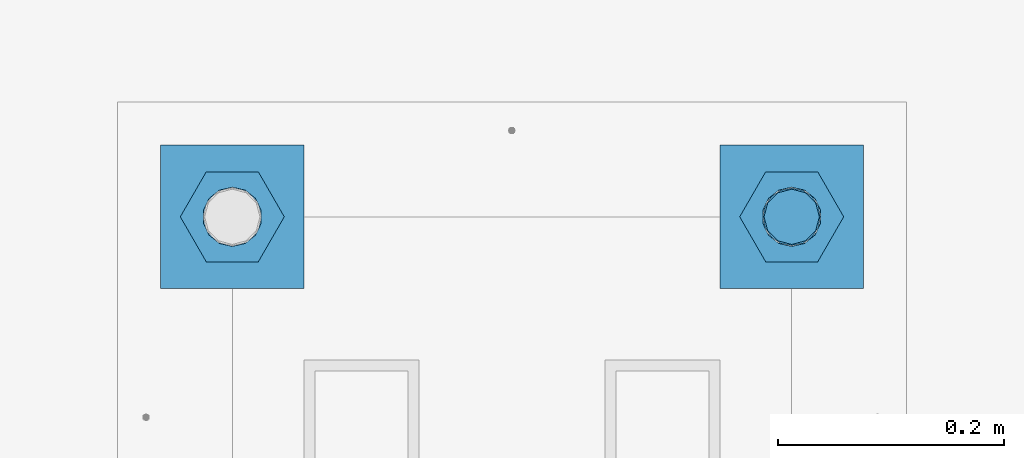
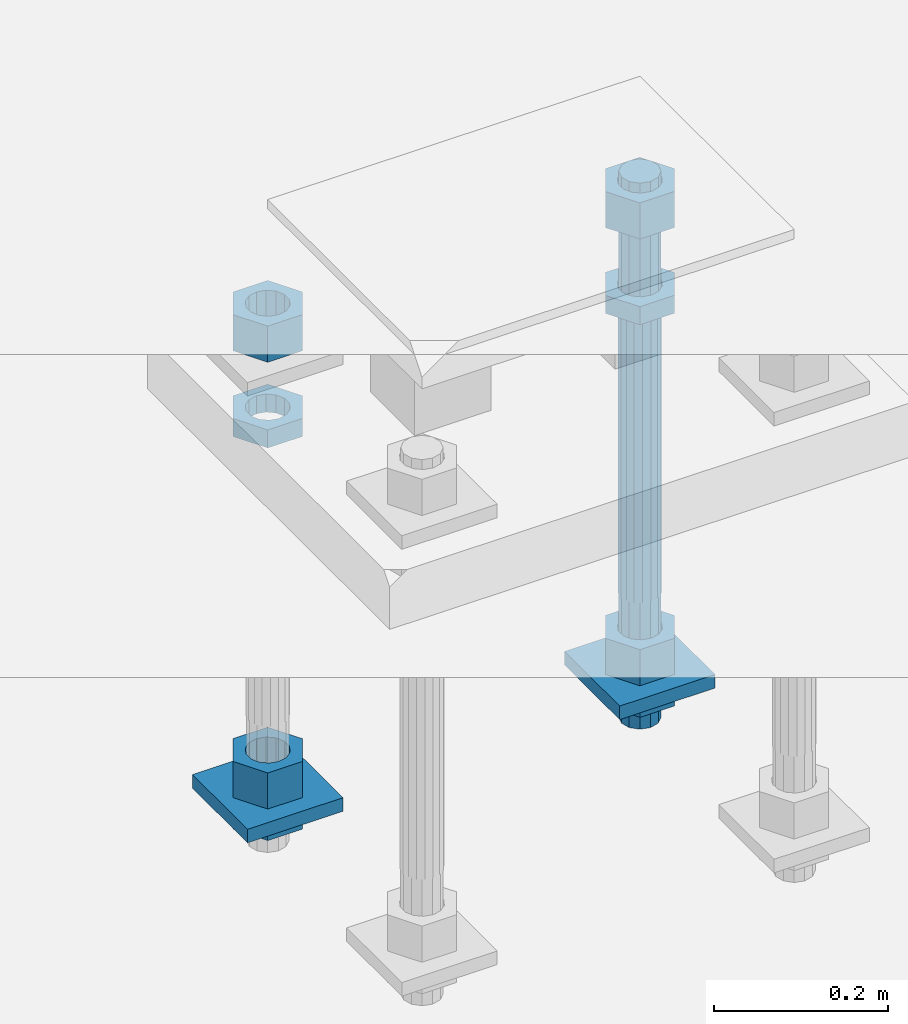
# One storey, part 2556 of 3843: 11 beams, 1 element without a shape of its own.
"""IFC2X3 building model written with IfcOpenShell, lengths in millimetres."""

from ifc_helpers import new_model, si_unit, frame, origin_with_axes, place, context, subcontext, project, spatial, faceted_brep, material, type_object, element, aggregate, save


model = new_model("IFC2X3")

# Units and contexts
model_context = context("Model", 3, precision=1e-05, world=origin_with_axes())
body_context = subcontext(model_context, "Body", "Model", "MODEL_VIEW")
ifc_project = project(units=[si_unit("LENGTHUNIT", "METRE", prefix="MILLI"), si_unit("AREAUNIT", "SQUARE_METRE"), si_unit("VOLUMEUNIT", "CUBIC_METRE"), si_unit("MASSUNIT", "GRAM", prefix="KILO"), si_unit("TIMEUNIT", "SECOND"), si_unit("PLANEANGLEUNIT", "RADIAN"), si_unit("SOLIDANGLEUNIT", "STERADIAN"), si_unit("THERMODYNAMICTEMPERATUREUNIT", "DEGREE_CELSIUS"), si_unit("LUMINOUSINTENSITYUNIT", "LUMEN")], contexts=[model_context])

# Site, building, storey
site_placement = place(None, origin_with_axes())
site = spatial("IfcSite", under=ifc_project, at=site_placement, CompositionType="ELEMENT")
building_placement = place(site_placement, origin_with_axes())
building = spatial("IfcBuilding", under=site, at=building_placement, Name="Undefined", CompositionType="ELEMENT")
storey_placement = place(building_placement, origin_with_axes())
storey = spatial("IfcBuildingStorey", under=building, at=storey_placement, Name="Undefined", CompositionType="ELEMENT", Elevation=0.0)

# Assembly, beams
assembly_placement = place(storey_placement, origin_with_axes())
assembly = element("IfcElementAssembly", 1, at=assembly_placement, inside=storey, Name="TEMPLATE", AssemblyPlace="NOTDEFINED", PredefinedType="RIGID_FRAME")
ifc_material_1 = material(Name="STEEL/A572-50")
beam_type_1 = type_object("IfcBeamType", PredefinedType="NOTDEFINED")
beam_1_placement = place(assembly_placement, frame((105403.65, 241.299998474126, 29244.925), z_axis=(-1.0, 0.0, 0.0), x_axis=(0.0, -1.0, 0.0)))
beam_1 = element("IfcBeam", 2, at=beam_1_placement, type_object=beam_type_1, material=ifc_material_1, Name="WASHER_PLATE", context=body_context, shape_type="Brep", body=[
    faceted_brep([(0.0, 9.52500000000146, -63.5), (0.0, 9.52500000000146, 63.5), (127.0, 9.52500000000146, 63.5), (127.0, 9.52500000000146, -63.5), (0.0, -9.52500000000146, 63.5), (127.0, -9.52500000000146, 63.5), (0.0, -9.52500000000146, -63.5), (127.0, -9.52500000000146, -63.5)], [[[0, 1, 2, 3]], [[1, 4, 5, 2]], [[4, 6, 7, 5]], [[6, 0, 3, 7]], [[5, 7, 3, 2]], [[6, 4, 1, 0]]]),
])
beam_2_placement = place(assembly_placement, frame((104908.35, 241.299998474126, 29244.925), z_axis=(-1.0, 0.0, 0.0), x_axis=(0.0, -1.0, 0.0)))
beam_2 = element("IfcBeam", 3, at=beam_2_placement, type_object=beam_type_1, material=ifc_material_1, Name="WASHER_PLATE", context=body_context, shape_type="Brep", body=[
    faceted_brep([(0.0, 9.52500000000146, -63.5), (0.0, 9.52500000000146, 63.5), (127.0, 9.52500000000146, 63.5), (127.0, 9.52500000000146, -63.5), (0.0, -9.52500000000146, 63.5), (127.0, -9.52500000000146, 63.5), (0.0, -9.52500000000146, -63.5), (127.0, -9.52500000000146, -63.5)], [[[0, 1, 2, 3]], [[1, 4, 5, 2]], [[4, 6, 7, 5]], [[6, 0, 3, 7]], [[5, 7, 3, 2]], [[6, 4, 1, 0]]]),
])
ifc_material_2 = material(Name="STEEL/A36")
beam_type_2 = type_object("IfcBeamType", Name="2_HALF_NUT", PredefinedType="NOTDEFINED")
beam_3_placement = place(assembly_placement, frame((105403.65, 177.799998474126, 29787.85), z_axis=(0.0, -1.0, 0.0), x_axis=(0.0, 0.0, -1.0)))
beam_3 = element("IfcBeam", 4, at=beam_3_placement, type_object=beam_type_2, material=ifc_material_2, Name="NUT", ObjectType="2_HALF_NUT", context=body_context, shape_type="Brep", body=[
    faceted_brep([(0.0, -46.0369987487793, 0.0), (0.0, -23.0184993743896, -39.869213104248), (25.4000000000015, -23.0184993743896, -39.869213104248), (25.4000000000015, -46.0369987487793, 0.0), (0.0, 23.0184993743896, -39.869213104248), (25.4000000000015, 23.0184993743896, -39.869213104248), (0.0, 46.0369987487793, 0.0), (25.4000000000015, 46.0369987487793, 0.0), (0.0, 23.0184993743896, 39.869213104248), (25.4000000000015, 23.0184993743896, 39.869213104248), (0.0, -23.0184993743896, 39.869213104248), (25.4000000000015, -23.0184993743896, 39.869213104248), (0.0, 0.0, 26.1940002441406), (0.0, 11.3650617044477, 23.5999013092805), (25.4000000000015, 11.3650617044477, 23.5999013092805), (25.4000000000015, 0.0, 26.1940002441406), (0.0, 20.4791109456419, 16.3316083006721), (25.4000000000015, 20.4791109456419, 16.3316083006721), (0.0, 25.5370200498292, 5.82867859874386), (25.4000000000015, 25.5370200498292, 5.82867859874386), (0.0, 25.5370200498292, -5.82867859874386), (25.4000000000015, 25.5370200498292, -5.82867859874386), (0.0, 20.4791109456419, -16.3316083006721), (25.4000000000015, 20.4791109456419, -16.3316083006721), (0.0, 11.3650617044477, -23.5999013092805), (25.4000000000015, 11.3650617044477, -23.5999013092805), (0.0, 0.0, -26.1940002441406), (25.4000000000015, 0.0, -26.1940002441406), (0.0, -11.3650617044477, -23.5999013092805), (25.4000000000015, -11.3650617044477, -23.5999013092805), (0.0, -20.4791109456419, -16.3316083006721), (25.4000000000015, -20.4791109456419, -16.3316083006721), (0.0, -25.5370200498292, -5.82867859874386), (25.4000000000015, -25.5370200498292, -5.82867859874386), (0.0, -25.5370200498292, 5.82867859874386), (25.4000000000015, -25.5370200498292, 5.82867859874386), (0.0, -20.4791109456419, 16.3316083006721), (25.4000000000015, -20.4791109456419, 16.3316083006721), (0.0, -11.3650617044477, 23.5999013092805), (25.4000000000015, -11.3650617044477, 23.5999013092805)], [[[0, 1, 2, 3]], [[1, 4, 5, 2]], [[4, 6, 7, 5]], [[6, 8, 9, 7]], [[8, 10, 11, 9]], [[10, 0, 3, 11]], [[12, 13, 14, 15]], [[13, 16, 17, 14]], [[16, 18, 19, 17]], [[18, 20, 21, 19]], [[20, 22, 23, 21]], [[22, 24, 25, 23]], [[24, 26, 27, 25]], [[26, 28, 29, 27]], [[28, 30, 31, 29]], [[30, 32, 33, 31]], [[32, 34, 35, 33]], [[34, 36, 37, 35]], [[36, 38, 39, 37]], [[38, 12, 15, 39]], [[5, 7, 9, 11, 3, 2], [17, 19, 21, 23, 25, 27, 29, 31, 33, 35, 37, 39, 15, 14]], [[10, 8, 6, 4, 1, 0], [38, 36, 34, 32, 30, 28, 26, 24, 22, 20, 18, 16, 13, 12]]]),
])
beam_4_placement = place(assembly_placement, frame((105403.65, 177.799998474126, 29235.4), z_axis=(0.0, -1.0, 0.0), x_axis=(0.0, 0.0, -1.0)))
beam_4 = element("IfcBeam", 5, at=beam_4_placement, type_object=beam_type_2, material=ifc_material_2, Name="NUT", ObjectType="2_HALF_NUT", context=body_context, shape_type="Brep", body=[
    faceted_brep([(0.0, -46.0369987487793, 0.0), (0.0, -23.0184993743896, -39.869213104248), (25.4000000000015, -23.0184993743896, -39.869213104248), (25.4000000000015, -46.0369987487793, 0.0), (0.0, 23.0184993743896, -39.869213104248), (25.4000000000015, 23.0184993743896, -39.869213104248), (0.0, 46.0369987487793, 0.0), (25.4000000000015, 46.0369987487793, 0.0), (0.0, 23.0184993743896, 39.869213104248), (25.4000000000015, 23.0184993743896, 39.869213104248), (0.0, -23.0184993743896, 39.869213104248), (25.4000000000015, -23.0184993743896, 39.869213104248), (0.0, 0.0, 26.1940002441406), (0.0, 11.3650617044477, 23.5999013092805), (25.4000000000015, 11.3650617044477, 23.5999013092805), (25.4000000000015, 0.0, 26.1940002441406), (0.0, 20.4791109456419, 16.3316083006721), (25.4000000000015, 20.4791109456419, 16.3316083006721), (0.0, 25.5370200498292, 5.82867859874386), (25.4000000000015, 25.5370200498292, 5.82867859874386), (0.0, 25.5370200498292, -5.82867859874386), (25.4000000000015, 25.5370200498292, -5.82867859874386), (0.0, 20.4791109456419, -16.3316083006721), (25.4000000000015, 20.4791109456419, -16.3316083006721), (0.0, 11.3650617044477, -23.5999013092805), (25.4000000000015, 11.3650617044477, -23.5999013092805), (0.0, 0.0, -26.1940002441406), (25.4000000000015, 0.0, -26.1940002441406), (0.0, -11.3650617044477, -23.5999013092805), (25.4000000000015, -11.3650617044477, -23.5999013092805), (0.0, -20.4791109456419, -16.3316083006721), (25.4000000000015, -20.4791109456419, -16.3316083006721), (0.0, -25.5370200498292, -5.82867859874386), (25.4000000000015, -25.5370200498292, -5.82867859874386), (0.0, -25.5370200498292, 5.82867859874386), (25.4000000000015, -25.5370200498292, 5.82867859874386), (0.0, -20.4791109456419, 16.3316083006721), (25.4000000000015, -20.4791109456419, 16.3316083006721), (0.0, -11.3650617044477, 23.5999013092805), (25.4000000000015, -11.3650617044477, 23.5999013092805)], [[[0, 1, 2, 3]], [[1, 4, 5, 2]], [[4, 6, 7, 5]], [[6, 8, 9, 7]], [[8, 10, 11, 9]], [[10, 0, 3, 11]], [[12, 13, 14, 15]], [[13, 16, 17, 14]], [[16, 18, 19, 17]], [[18, 20, 21, 19]], [[20, 22, 23, 21]], [[22, 24, 25, 23]], [[24, 26, 27, 25]], [[26, 28, 29, 27]], [[28, 30, 31, 29]], [[30, 32, 33, 31]], [[32, 34, 35, 33]], [[34, 36, 37, 35]], [[36, 38, 39, 37]], [[38, 12, 15, 39]], [[5, 7, 9, 11, 3, 2], [17, 19, 21, 23, 25, 27, 29, 31, 33, 35, 37, 39, 15, 14]], [[10, 8, 6, 4, 1, 0], [38, 36, 34, 32, 30, 28, 26, 24, 22, 20, 18, 16, 13, 12]]]),
])
beam_5_placement = place(assembly_placement, frame((104908.35, 177.799998474126, 29787.85), z_axis=(0.0, -1.0, 0.0), x_axis=(0.0, 0.0, -1.0)))
beam_5 = element("IfcBeam", 6, at=beam_5_placement, type_object=beam_type_2, material=ifc_material_2, Name="NUT", ObjectType="2_HALF_NUT", context=body_context, shape_type="Brep", body=[
    faceted_brep([(0.0, -46.0369987487793, 0.0), (0.0, -23.0184993743896, -39.869213104248), (25.4000000000015, -23.0184993743896, -39.869213104248), (25.4000000000015, -46.0369987487793, 0.0), (0.0, 23.0184993743896, -39.869213104248), (25.4000000000015, 23.0184993743896, -39.869213104248), (0.0, 46.0369987487793, 0.0), (25.4000000000015, 46.0369987487793, 0.0), (0.0, 23.0184993743896, 39.869213104248), (25.4000000000015, 23.0184993743896, 39.869213104248), (0.0, -23.0184993743896, 39.869213104248), (25.4000000000015, -23.0184993743896, 39.869213104248), (0.0, 0.0, 26.1940002441406), (0.0, 11.3650617044477, 23.5999013092805), (25.4000000000015, 11.3650617044477, 23.5999013092805), (25.4000000000015, 0.0, 26.1940002441406), (0.0, 20.4791109456419, 16.3316083006721), (25.4000000000015, 20.4791109456419, 16.3316083006721), (0.0, 25.5370200498292, 5.82867859874386), (25.4000000000015, 25.5370200498292, 5.82867859874386), (0.0, 25.5370200498292, -5.82867859874386), (25.4000000000015, 25.5370200498292, -5.82867859874386), (0.0, 20.4791109456419, -16.3316083006721), (25.4000000000015, 20.4791109456419, -16.3316083006721), (0.0, 11.3650617044477, -23.5999013092805), (25.4000000000015, 11.3650617044477, -23.5999013092805), (0.0, 0.0, -26.1940002441406), (25.4000000000015, 0.0, -26.1940002441406), (0.0, -11.3650617044477, -23.5999013092805), (25.4000000000015, -11.3650617044477, -23.5999013092805), (0.0, -20.4791109456419, -16.3316083006721), (25.4000000000015, -20.4791109456419, -16.3316083006721), (0.0, -25.5370200498292, -5.82867859874386), (25.4000000000015, -25.5370200498292, -5.82867859874386), (0.0, -25.5370200498292, 5.82867859874386), (25.4000000000015, -25.5370200498292, 5.82867859874386), (0.0, -20.4791109456419, 16.3316083006721), (25.4000000000015, -20.4791109456419, 16.3316083006721), (0.0, -11.3650617044477, 23.5999013092805), (25.4000000000015, -11.3650617044477, 23.5999013092805)], [[[0, 1, 2, 3]], [[1, 4, 5, 2]], [[4, 6, 7, 5]], [[6, 8, 9, 7]], [[8, 10, 11, 9]], [[10, 0, 3, 11]], [[12, 13, 14, 15]], [[13, 16, 17, 14]], [[16, 18, 19, 17]], [[18, 20, 21, 19]], [[20, 22, 23, 21]], [[22, 24, 25, 23]], [[24, 26, 27, 25]], [[26, 28, 29, 27]], [[28, 30, 31, 29]], [[30, 32, 33, 31]], [[32, 34, 35, 33]], [[34, 36, 37, 35]], [[36, 38, 39, 37]], [[38, 12, 15, 39]], [[5, 7, 9, 11, 3, 2], [17, 19, 21, 23, 25, 27, 29, 31, 33, 35, 37, 39, 15, 14]], [[10, 8, 6, 4, 1, 0], [38, 36, 34, 32, 30, 28, 26, 24, 22, 20, 18, 16, 13, 12]]]),
])
beam_6_placement = place(assembly_placement, frame((104908.35, 177.799998474126, 29235.4), z_axis=(0.0, -1.0, 0.0), x_axis=(0.0, 0.0, -1.0)))
beam_6 = element("IfcBeam", 7, at=beam_6_placement, type_object=beam_type_2, material=ifc_material_2, Name="NUT", ObjectType="2_HALF_NUT", context=body_context, shape_type="Brep", body=[
    faceted_brep([(0.0, -46.0369987487793, 0.0), (0.0, -23.0184993743896, -39.869213104248), (25.4000000000015, -23.0184993743896, -39.869213104248), (25.4000000000015, -46.0369987487793, 0.0), (0.0, 23.0184993743896, -39.869213104248), (25.4000000000015, 23.0184993743896, -39.869213104248), (0.0, 46.0369987487793, 0.0), (25.4000000000015, 46.0369987487793, 0.0), (0.0, 23.0184993743896, 39.869213104248), (25.4000000000015, 23.0184993743896, 39.869213104248), (0.0, -23.0184993743896, 39.869213104248), (25.4000000000015, -23.0184993743896, 39.869213104248), (0.0, 0.0, 26.1940002441406), (0.0, 11.3650617044477, 23.5999013092805), (25.4000000000015, 11.3650617044477, 23.5999013092805), (25.4000000000015, 0.0, 26.1940002441406), (0.0, 20.4791109456419, 16.3316083006721), (25.4000000000015, 20.4791109456419, 16.3316083006721), (0.0, 25.5370200498292, 5.82867859874386), (25.4000000000015, 25.5370200498292, 5.82867859874386), (0.0, 25.5370200498292, -5.82867859874386), (25.4000000000015, 25.5370200498292, -5.82867859874386), (0.0, 20.4791109456419, -16.3316083006721), (25.4000000000015, 20.4791109456419, -16.3316083006721), (0.0, 11.3650617044477, -23.5999013092805), (25.4000000000015, 11.3650617044477, -23.5999013092805), (0.0, 0.0, -26.1940002441406), (25.4000000000015, 0.0, -26.1940002441406), (0.0, -11.3650617044477, -23.5999013092805), (25.4000000000015, -11.3650617044477, -23.5999013092805), (0.0, -20.4791109456419, -16.3316083006721), (25.4000000000015, -20.4791109456419, -16.3316083006721), (0.0, -25.5370200498292, -5.82867859874386), (25.4000000000015, -25.5370200498292, -5.82867859874386), (0.0, -25.5370200498292, 5.82867859874386), (25.4000000000015, -25.5370200498292, 5.82867859874386), (0.0, -20.4791109456419, 16.3316083006721), (25.4000000000015, -20.4791109456419, 16.3316083006721), (0.0, -11.3650617044477, 23.5999013092805), (25.4000000000015, -11.3650617044477, 23.5999013092805)], [[[0, 1, 2, 3]], [[1, 4, 5, 2]], [[4, 6, 7, 5]], [[6, 8, 9, 7]], [[8, 10, 11, 9]], [[10, 0, 3, 11]], [[12, 13, 14, 15]], [[13, 16, 17, 14]], [[16, 18, 19, 17]], [[18, 20, 21, 19]], [[20, 22, 23, 21]], [[22, 24, 25, 23]], [[24, 26, 27, 25]], [[26, 28, 29, 27]], [[28, 30, 31, 29]], [[30, 32, 33, 31]], [[32, 34, 35, 33]], [[34, 36, 37, 35]], [[36, 38, 39, 37]], [[38, 12, 15, 39]], [[5, 7, 9, 11, 3, 2], [17, 19, 21, 23, 25, 27, 29, 31, 33, 35, 37, 39, 15, 14]], [[10, 8, 6, 4, 1, 0], [38, 36, 34, 32, 30, 28, 26, 24, 22, 20, 18, 16, 13, 12]]]),
])
beam_type_3 = type_object("IfcBeamType", Name="2_HEAVY_HEX_NUT", PredefinedType="NOTDEFINED")
beam_7_placement = place(assembly_placement, frame((105403.65, 177.799998474126, 29933.9), z_axis=(0.0, -1.0, 0.0), x_axis=(0.0, 0.0, -1.0)))
beam_7 = element("IfcBeam", 8, at=beam_7_placement, type_object=beam_type_3, material=ifc_material_2, Name="NUT", ObjectType="2_HEAVY_HEX_NUT", context=body_context, shape_type="Brep", body=[
    faceted_brep([(0.0, -46.0369987487793, 0.0), (0.0, -23.0184993743896, -39.869213104248), (50.7999999999993, -23.0184993743896, -39.869213104248), (50.7999999999993, -46.0369987487793, 0.0), (0.0, 23.0184993743896, -39.869213104248), (50.7999999999993, 23.0184993743896, -39.869213104248), (0.0, 46.0369987487793, 0.0), (50.7999999999993, 46.0369987487793, 0.0), (0.0, 23.0184993743896, 39.869213104248), (50.7999999999993, 23.0184993743896, 39.869213104248), (0.0, -23.0184993743896, 39.869213104248), (50.7999999999993, -23.0184993743896, 39.869213104248), (0.0, 0.0, 26.1940002441406), (0.0, 11.3650617044477, 23.5999013092805), (50.7999999999993, 11.3650617044477, 23.5999013092805), (50.7999999999993, 0.0, 26.1940002441406), (0.0, 20.4791109456419, 16.3316083006721), (50.7999999999993, 20.4791109456419, 16.3316083006721), (0.0, 25.5370200498292, 5.82867859874386), (50.7999999999993, 25.5370200498292, 5.82867859874386), (0.0, 25.5370200498292, -5.82867859874386), (50.7999999999993, 25.5370200498292, -5.82867859874386), (0.0, 20.4791109456419, -16.3316083006721), (50.7999999999993, 20.4791109456419, -16.3316083006721), (0.0, 11.3650617044477, -23.5999013092805), (50.7999999999993, 11.3650617044477, -23.5999013092805), (0.0, 0.0, -26.1940002441406), (50.7999999999993, 0.0, -26.1940002441406), (0.0, -11.3650617044477, -23.5999013092805), (50.7999999999993, -11.3650617044477, -23.5999013092805), (0.0, -20.4791109456419, -16.3316083006721), (50.7999999999993, -20.4791109456419, -16.3316083006721), (0.0, -25.5370200498292, -5.82867859874386), (50.7999999999993, -25.5370200498292, -5.82867859874386), (0.0, -25.5370200498292, 5.82867859874386), (50.7999999999993, -25.5370200498292, 5.82867859874386), (0.0, -20.4791109456419, 16.3316083006721), (50.7999999999993, -20.4791109456419, 16.3316083006721), (0.0, -11.3650617044477, 23.5999013092805), (50.7999999999993, -11.3650617044477, 23.5999013092805)], [[[0, 1, 2, 3]], [[1, 4, 5, 2]], [[4, 6, 7, 5]], [[6, 8, 9, 7]], [[8, 10, 11, 9]], [[10, 0, 3, 11]], [[12, 13, 14, 15]], [[13, 16, 17, 14]], [[16, 18, 19, 17]], [[18, 20, 21, 19]], [[20, 22, 23, 21]], [[22, 24, 25, 23]], [[24, 26, 27, 25]], [[26, 28, 29, 27]], [[28, 30, 31, 29]], [[30, 32, 33, 31]], [[32, 34, 35, 33]], [[34, 36, 37, 35]], [[36, 38, 39, 37]], [[38, 12, 15, 39]], [[5, 7, 9, 11, 3, 2], [17, 19, 21, 23, 25, 27, 29, 31, 33, 35, 37, 39, 15, 14]], [[10, 8, 6, 4, 1, 0], [38, 36, 34, 32, 30, 28, 26, 24, 22, 20, 18, 16, 13, 12]]]),
])
beam_8_placement = place(assembly_placement, frame((105403.65, 177.799998474126, 29305.25), z_axis=(0.0, -1.0, 0.0), x_axis=(0.0, 0.0, -1.0)))
beam_8 = element("IfcBeam", 9, at=beam_8_placement, type_object=beam_type_3, material=ifc_material_2, Name="NUT", ObjectType="2_HEAVY_HEX_NUT", context=body_context, shape_type="Brep", body=[
    faceted_brep([(0.0, -46.0369987487793, 0.0), (0.0, -23.0184993743896, -39.869213104248), (50.7999999999993, -23.0184993743896, -39.869213104248), (50.7999999999993, -46.0369987487793, 0.0), (0.0, 23.0184993743896, -39.869213104248), (50.7999999999993, 23.0184993743896, -39.869213104248), (0.0, 46.0369987487793, 0.0), (50.7999999999993, 46.0369987487793, 0.0), (0.0, 23.0184993743896, 39.869213104248), (50.7999999999993, 23.0184993743896, 39.869213104248), (0.0, -23.0184993743896, 39.869213104248), (50.7999999999993, -23.0184993743896, 39.869213104248), (0.0, 0.0, 26.1940002441406), (0.0, 11.3650617044477, 23.5999013092805), (50.7999999999993, 11.3650617044477, 23.5999013092805), (50.7999999999993, 0.0, 26.1940002441406), (0.0, 20.4791109456419, 16.3316083006721), (50.7999999999993, 20.4791109456419, 16.3316083006721), (0.0, 25.5370200498292, 5.82867859874386), (50.7999999999993, 25.5370200498292, 5.82867859874386), (0.0, 25.5370200498292, -5.82867859874386), (50.7999999999993, 25.5370200498292, -5.82867859874386), (0.0, 20.4791109456419, -16.3316083006721), (50.7999999999993, 20.4791109456419, -16.3316083006721), (0.0, 11.3650617044477, -23.5999013092805), (50.7999999999993, 11.3650617044477, -23.5999013092805), (0.0, 0.0, -26.1940002441406), (50.7999999999993, 0.0, -26.1940002441406), (0.0, -11.3650617044477, -23.5999013092805), (50.7999999999993, -11.3650617044477, -23.5999013092805), (0.0, -20.4791109456419, -16.3316083006721), (50.7999999999993, -20.4791109456419, -16.3316083006721), (0.0, -25.5370200498292, -5.82867859874386), (50.7999999999993, -25.5370200498292, -5.82867859874386), (0.0, -25.5370200498292, 5.82867859874386), (50.7999999999993, -25.5370200498292, 5.82867859874386), (0.0, -20.4791109456419, 16.3316083006721), (50.7999999999993, -20.4791109456419, 16.3316083006721), (0.0, -11.3650617044477, 23.5999013092805), (50.7999999999993, -11.3650617044477, 23.5999013092805)], [[[0, 1, 2, 3]], [[1, 4, 5, 2]], [[4, 6, 7, 5]], [[6, 8, 9, 7]], [[8, 10, 11, 9]], [[10, 0, 3, 11]], [[12, 13, 14, 15]], [[13, 16, 17, 14]], [[16, 18, 19, 17]], [[18, 20, 21, 19]], [[20, 22, 23, 21]], [[22, 24, 25, 23]], [[24, 26, 27, 25]], [[26, 28, 29, 27]], [[28, 30, 31, 29]], [[30, 32, 33, 31]], [[32, 34, 35, 33]], [[34, 36, 37, 35]], [[36, 38, 39, 37]], [[38, 12, 15, 39]], [[5, 7, 9, 11, 3, 2], [17, 19, 21, 23, 25, 27, 29, 31, 33, 35, 37, 39, 15, 14]], [[10, 8, 6, 4, 1, 0], [38, 36, 34, 32, 30, 28, 26, 24, 22, 20, 18, 16, 13, 12]]]),
])
beam_9_placement = place(assembly_placement, frame((104908.35, 177.799998474126, 29933.9), z_axis=(0.0, -1.0, 0.0), x_axis=(0.0, 0.0, -1.0)))
beam_9 = element("IfcBeam", 10, at=beam_9_placement, type_object=beam_type_3, material=ifc_material_2, Name="NUT", ObjectType="2_HEAVY_HEX_NUT", context=body_context, shape_type="Brep", body=[
    faceted_brep([(0.0, -46.0369987487793, 0.0), (0.0, -23.0184993743896, -39.869213104248), (50.7999999999993, -23.0184993743896, -39.869213104248), (50.7999999999993, -46.0369987487793, 0.0), (0.0, 23.0184993743896, -39.869213104248), (50.7999999999993, 23.0184993743896, -39.869213104248), (0.0, 46.0369987487793, 0.0), (50.7999999999993, 46.0369987487793, 0.0), (0.0, 23.0184993743896, 39.869213104248), (50.7999999999993, 23.0184993743896, 39.869213104248), (0.0, -23.0184993743896, 39.869213104248), (50.7999999999993, -23.0184993743896, 39.869213104248), (0.0, 0.0, 26.1940002441406), (0.0, 11.3650617044477, 23.5999013092805), (50.7999999999993, 11.3650617044477, 23.5999013092805), (50.7999999999993, 0.0, 26.1940002441406), (0.0, 20.4791109456419, 16.3316083006721), (50.7999999999993, 20.4791109456419, 16.3316083006721), (0.0, 25.5370200498292, 5.82867859874386), (50.7999999999993, 25.5370200498292, 5.82867859874386), (0.0, 25.5370200498292, -5.82867859874386), (50.7999999999993, 25.5370200498292, -5.82867859874386), (0.0, 20.4791109456419, -16.3316083006721), (50.7999999999993, 20.4791109456419, -16.3316083006721), (0.0, 11.3650617044477, -23.5999013092805), (50.7999999999993, 11.3650617044477, -23.5999013092805), (0.0, 0.0, -26.1940002441406), (50.7999999999993, 0.0, -26.1940002441406), (0.0, -11.3650617044477, -23.5999013092805), (50.7999999999993, -11.3650617044477, -23.5999013092805), (0.0, -20.4791109456419, -16.3316083006721), (50.7999999999993, -20.4791109456419, -16.3316083006721), (0.0, -25.5370200498292, -5.82867859874386), (50.7999999999993, -25.5370200498292, -5.82867859874386), (0.0, -25.5370200498292, 5.82867859874386), (50.7999999999993, -25.5370200498292, 5.82867859874386), (0.0, -20.4791109456419, 16.3316083006721), (50.7999999999993, -20.4791109456419, 16.3316083006721), (0.0, -11.3650617044477, 23.5999013092805), (50.7999999999993, -11.3650617044477, 23.5999013092805)], [[[0, 1, 2, 3]], [[1, 4, 5, 2]], [[4, 6, 7, 5]], [[6, 8, 9, 7]], [[8, 10, 11, 9]], [[10, 0, 3, 11]], [[12, 13, 14, 15]], [[13, 16, 17, 14]], [[16, 18, 19, 17]], [[18, 20, 21, 19]], [[20, 22, 23, 21]], [[22, 24, 25, 23]], [[24, 26, 27, 25]], [[26, 28, 29, 27]], [[28, 30, 31, 29]], [[30, 32, 33, 31]], [[32, 34, 35, 33]], [[34, 36, 37, 35]], [[36, 38, 39, 37]], [[38, 12, 15, 39]], [[5, 7, 9, 11, 3, 2], [17, 19, 21, 23, 25, 27, 29, 31, 33, 35, 37, 39, 15, 14]], [[10, 8, 6, 4, 1, 0], [38, 36, 34, 32, 30, 28, 26, 24, 22, 20, 18, 16, 13, 12]]]),
])
beam_10_placement = place(assembly_placement, frame((104908.35, 177.799998474126, 29305.25), z_axis=(0.0, -1.0, 0.0), x_axis=(0.0, 0.0, -1.0)))
beam_10 = element("IfcBeam", 11, at=beam_10_placement, type_object=beam_type_3, material=ifc_material_2, Name="NUT", ObjectType="2_HEAVY_HEX_NUT", context=body_context, shape_type="Brep", body=[
    faceted_brep([(0.0, -46.0369987487793, 0.0), (0.0, -23.0184993743896, -39.869213104248), (50.7999999999993, -23.0184993743896, -39.869213104248), (50.7999999999993, -46.0369987487793, 0.0), (0.0, 23.0184993743896, -39.869213104248), (50.7999999999993, 23.0184993743896, -39.869213104248), (0.0, 46.0369987487793, 0.0), (50.7999999999993, 46.0369987487793, 0.0), (0.0, 23.0184993743896, 39.869213104248), (50.7999999999993, 23.0184993743896, 39.869213104248), (0.0, -23.0184993743896, 39.869213104248), (50.7999999999993, -23.0184993743896, 39.869213104248), (0.0, 0.0, 26.1940002441406), (0.0, 11.3650617044477, 23.5999013092805), (50.7999999999993, 11.3650617044477, 23.5999013092805), (50.7999999999993, 0.0, 26.1940002441406), (0.0, 20.4791109456419, 16.3316083006721), (50.7999999999993, 20.4791109456419, 16.3316083006721), (0.0, 25.5370200498292, 5.82867859874386), (50.7999999999993, 25.5370200498292, 5.82867859874386), (0.0, 25.5370200498292, -5.82867859874386), (50.7999999999993, 25.5370200498292, -5.82867859874386), (0.0, 20.4791109456419, -16.3316083006721), (50.7999999999993, 20.4791109456419, -16.3316083006721), (0.0, 11.3650617044477, -23.5999013092805), (50.7999999999993, 11.3650617044477, -23.5999013092805), (0.0, 0.0, -26.1940002441406), (50.7999999999993, 0.0, -26.1940002441406), (0.0, -11.3650617044477, -23.5999013092805), (50.7999999999993, -11.3650617044477, -23.5999013092805), (0.0, -20.4791109456419, -16.3316083006721), (50.7999999999993, -20.4791109456419, -16.3316083006721), (0.0, -25.5370200498292, -5.82867859874386), (50.7999999999993, -25.5370200498292, -5.82867859874386), (0.0, -25.5370200498292, 5.82867859874386), (50.7999999999993, -25.5370200498292, 5.82867859874386), (0.0, -20.4791109456419, 16.3316083006721), (50.7999999999993, -20.4791109456419, 16.3316083006721), (0.0, -11.3650617044477, 23.5999013092805), (50.7999999999993, -11.3650617044477, 23.5999013092805)], [[[0, 1, 2, 3]], [[1, 4, 5, 2]], [[4, 6, 7, 5]], [[6, 8, 9, 7]], [[8, 10, 11, 9]], [[10, 0, 3, 11]], [[12, 13, 14, 15]], [[13, 16, 17, 14]], [[16, 18, 19, 17]], [[18, 20, 21, 19]], [[20, 22, 23, 21]], [[22, 24, 25, 23]], [[24, 26, 27, 25]], [[26, 28, 29, 27]], [[28, 30, 31, 29]], [[30, 32, 33, 31]], [[32, 34, 35, 33]], [[34, 36, 37, 35]], [[36, 38, 39, 37]], [[38, 12, 15, 39]], [[5, 7, 9, 11, 3, 2], [17, 19, 21, 23, 25, 27, 29, 31, 33, 35, 37, 39, 15, 14]], [[10, 8, 6, 4, 1, 0], [38, 36, 34, 32, 30, 28, 26, 24, 22, 20, 18, 16, 13, 12]]]),
])
ifc_material_3 = material()
beam_type_4 = type_object("IfcBeamType", PredefinedType="NOTDEFINED")
beam_11_placement = place(assembly_placement, frame((105403.65, 177.799998474126, 29762.45), z_axis=(0.0, -1.0, 0.0), x_axis=(0.0, 0.0, -1.0)))
beam_11 = element("IfcBeam", 12, at=beam_11_placement, type_object=beam_type_4, material=ifc_material_3, Name="ANCHOR_ROD", context=body_context, shape_type="Brep", body=[
    faceted_brep([(-184.150000000001, -21.217622392709, 12.25), (-184.150000000001, -12.2499999999854, 21.2176223927163), (-184.150000000001, 1.45519152283669e-11, 24.5), (-184.150000000001, 12.2500000000146, 21.2176223927163), (-184.150000000001, 21.2176223927381, 12.25), (-184.150000000001, 24.5000000000146, 0.0), (-184.150000000001, 21.2176223927381, -12.25), (-184.150000000001, 12.2500000000146, -21.2176223927163), (-184.150000000001, 1.45519152283669e-11, -24.5), (-184.150000000001, -12.2499999999854, -21.2176223927163), (-184.150000000001, -21.217622392709, -12.25), (-184.150000000001, -24.4999999999854, 0.0), (0.0, 24.5000000000146, 0.0), (0.0, 21.2176223927381, -12.25), (0.0, 12.2500000000146, -21.2176223927163), (0.0, 1.45519152283669e-11, -24.5), (0.0, -12.2499999999854, -21.2176223927163), (0.0, -21.217622392709, -12.25), (0.0, -24.4999999999854, 0.0), (0.0, -21.217622392709, 12.25), (0.0, -12.2499999999854, 21.2176223927163), (0.0, 1.45519152283669e-11, 24.5), (0.0, 12.2500000000146, 21.2176223927163), (0.0, 21.2176223927381, 12.25), (0.0, -23.4665401257807, 9.72015918207035), (0.0, -17.9605122421344, 17.9605122421417), (0.0, -9.72015918207762, 23.466540125788), (0.0, 0.0, 25.4000000000015), (0.0, 9.72015918207762, 23.466540125788), (0.0, 17.9605122421344, 17.9605122421417), (0.0, 23.4665401257807, 9.72015918207035), (0.0, 25.3999996185303, 0.0), (0.0, 23.4665401257807, -9.72015918207035), (0.0, 17.9605122421344, -17.9605122421417), (0.0, 9.72015918207762, -23.466540125788), (0.0, 0.0, -25.4000000000015), (0.0, -9.72015918207762, -23.466540125788), (0.0, -17.9605122421344, -17.9605122421417), (0.0, -23.4665401257807, -9.72015918207035), (0.0, -25.3999996185303, 0.0), (406.399999999998, -25.3999999999942, 0.0), (406.399999999998, -23.4665401257807, 9.72015918207035), (406.399999999998, -17.9605122421344, 17.9605122421417), (406.399999999998, -9.72015918207762, 23.466540125788), (406.399999999998, 0.0, 25.4000000000015), (406.399999999998, 9.72015918207762, 23.466540125788), (406.399999999998, 17.9605122421344, 17.9605122421417), (406.399999999998, 23.4665401257807, 9.72015918207035), (406.399999999998, 25.3999999999942, 0.0), (406.399999999998, 23.4665401257807, -9.72015918207035), (406.399999999998, 17.9605122421344, -17.9605122421417), (406.399999999998, 9.72015918207762, -23.466540125788), (406.399999999998, 0.0, -25.4000000000015), (406.399999999998, -9.72015918207762, -23.466540125788), (406.399999999998, -17.9605122421344, -17.9605122421417), (406.399999999998, -23.4665401257807, -9.72015918207035), (406.399999999998, -12.2499999999854, 21.2176223927163), (406.399999999998, 1.45519152283669e-11, 24.5), (406.399999999998, 12.2500000000146, 21.2176223927163), (406.399999999998, 21.2176223927381, 12.25), (406.399999999998, 24.5000000000146, 0.0), (406.399999999998, 21.2176223927381, -12.25), (406.399999999998, 12.2500000000146, -21.2176223927163), (406.399999999998, 1.45519152283669e-11, -24.5), (406.399999999998, -12.2499999999854, -21.2176223927163), (406.399999999998, -21.217622392709, -12.25), (406.399999999998, -24.4999999999854, 0.0), (406.399999999998, -21.217622392709, 12.25), (584.200000000001, -12.2499999999854, -21.2176223927163), (584.200000000001, 1.45519152283669e-11, -24.5), (584.200000000001, 12.2500000000146, -21.2176223927163), (584.200000000001, 21.2176223927381, -12.25), (584.200000000001, 24.5000000000146, 0.0), (584.200000000001, 21.2176223927381, 12.25), (584.200000000001, 12.2500000000146, 21.2176223927163), (584.200000000001, 1.45519152283669e-11, 24.5), (584.200000000001, -12.2499999999854, 21.2176223927163), (584.200000000001, -21.217622392709, 12.25), (584.200000000001, -24.4999999999854, 0.0), (584.200000000001, -21.217622392709, -12.25)], [[[0, 1, 2, 3, 4, 5, 6, 7, 8, 9, 10, 11]], [[6, 5, 12, 13]], [[7, 6, 13, 14]], [[8, 7, 14, 15]], [[9, 8, 15, 16]], [[10, 9, 16, 17]], [[11, 10, 17, 18]], [[0, 11, 18, 19]], [[1, 0, 19, 20]], [[2, 1, 20, 21]], [[3, 2, 21, 22]], [[4, 3, 22, 23]], [[5, 4, 23, 12]], [[24, 25, 26, 27, 28, 29, 30, 31, 32, 33, 34, 35, 36, 37, 38, 39], [22, 21, 20, 19, 18, 17, 16, 15, 14, 13, 12, 23]], [[24, 39, 40, 41]], [[25, 24, 41, 42]], [[26, 25, 42, 43]], [[27, 26, 43, 44]], [[28, 27, 44, 45]], [[29, 28, 45, 46]], [[30, 29, 46, 47]], [[31, 30, 47, 48]], [[32, 31, 48, 49]], [[33, 32, 49, 50]], [[34, 33, 50, 51]], [[35, 34, 51, 52]], [[36, 35, 52, 53]], [[37, 36, 53, 54]], [[38, 37, 54, 55]], [[39, 38, 55, 40]], [[54, 53, 52, 51, 50, 49, 48, 47, 46, 45, 44, 43, 42, 41, 40, 55], [56, 57, 58, 59, 60, 61, 62, 63, 64, 65, 66, 67]], [[68, 69, 70, 71, 72, 73, 74, 75, 76, 77, 78, 79]], [[76, 75, 57, 56]], [[77, 76, 56, 67]], [[78, 77, 67, 66]], [[79, 78, 66, 65]], [[68, 79, 65, 64]], [[69, 68, 64, 63]], [[70, 69, 63, 62]], [[71, 70, 62, 61]], [[72, 71, 61, 60]], [[73, 72, 60, 59]], [[74, 73, 59, 58]], [[75, 74, 58, 57]]]),
])
aggregate(assembly, [beam_3, beam_7, beam_8, beam_4, beam_1, beam_11, beam_5, beam_9, beam_10, beam_6, beam_2])

save(model, "model.ifc")
